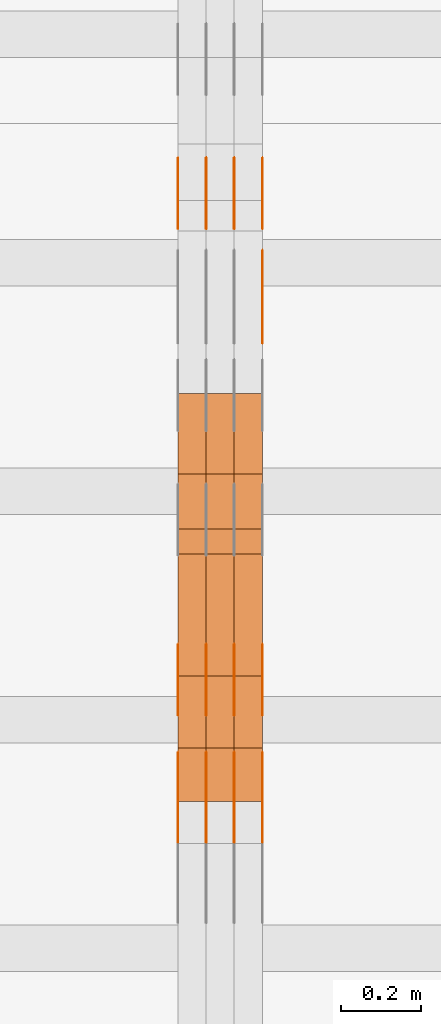
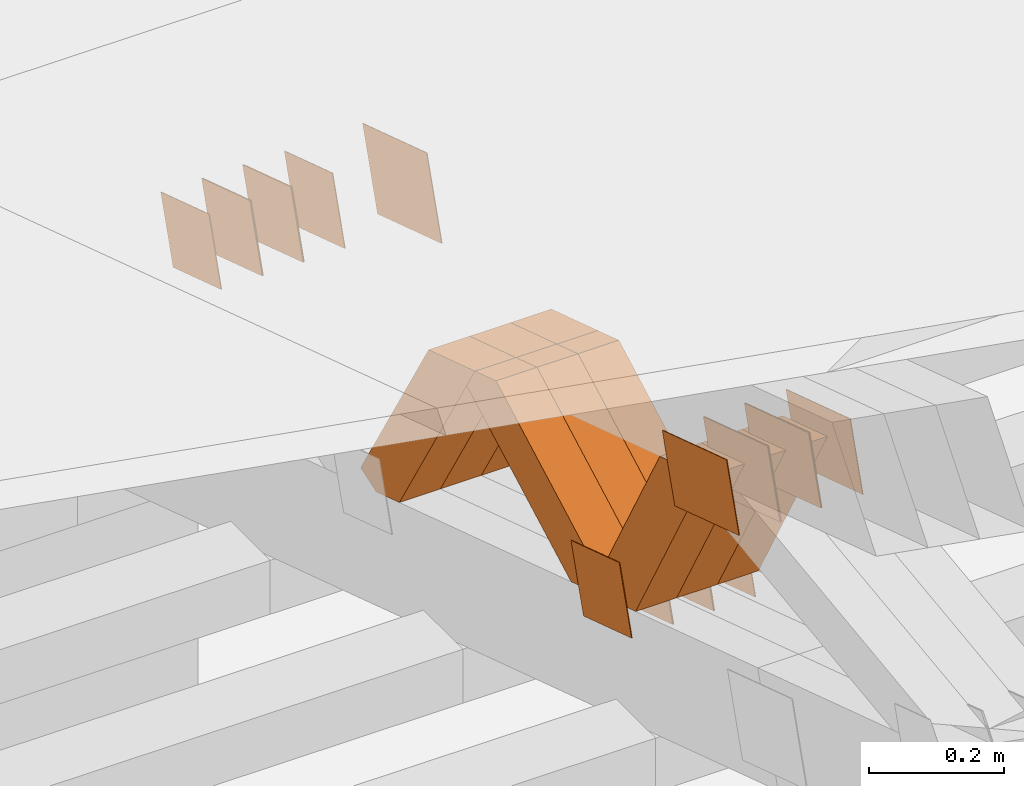
# One storey, part 210 of 385: 28 proxies.
"""IFC2X3 building model written with IfcOpenShell, lengths in millimetres."""

from ifc_helpers import new_model, entity, si_unit, converted_unit, derived_unit, direction, frame, origin, place, context, subcontext, project, spatial, polyline, outline, extrude, source, transform, mapped, material, type_object, type_shapes, element, save


model = new_model("IFC2X3")

# Units and contexts
model_context = context("Model", 3, precision=0.01, world=origin(), true_north=direction((6.12303176911189e-17, 1.0)))
body_context = subcontext(model_context, "Body", "Model", "MODEL_VIEW")
ifc_project = project(units=[si_unit("LENGTHUNIT", "METRE", prefix="MILLI"), si_unit("AREAUNIT", "SQUARE_METRE"), si_unit("VOLUMEUNIT", "CUBIC_METRE"), converted_unit("PLANEANGLEUNIT", "DEGREE", entity("IfcRatioMeasure", 0.0174532925199433), si_unit("PLANEANGLEUNIT", "RADIAN"), dimensions=[0, 0, 0, 0, 0, 0, 0]), si_unit("MASSUNIT", "GRAM", prefix="KILO"), derived_unit("MASSDENSITYUNIT", [(si_unit("MASSUNIT", "GRAM", prefix="KILO"), 1), (si_unit("LENGTHUNIT", "METRE"), -3)]), si_unit("TIMEUNIT", "SECOND"), si_unit("FREQUENCYUNIT", "HERTZ"), si_unit("THERMODYNAMICTEMPERATUREUNIT", "DEGREE_CELSIUS"), derived_unit("THERMALTRANSMITTANCEUNIT", [(si_unit("MASSUNIT", "GRAM", prefix="KILO"), 1), (si_unit("THERMODYNAMICTEMPERATUREUNIT", "KELVIN"), -1), (si_unit("TIMEUNIT", "SECOND"), -3)]), derived_unit("VOLUMETRICFLOWRATEUNIT", [(si_unit("LENGTHUNIT", "METRE"), 3), (si_unit("TIMEUNIT", "SECOND"), -1)]), si_unit("ELECTRICCURRENTUNIT", "AMPERE"), si_unit("ELECTRICVOLTAGEUNIT", "VOLT"), si_unit("POWERUNIT", "WATT"), si_unit("FORCEUNIT", "NEWTON", prefix="KILO"), si_unit("ILLUMINANCEUNIT", "LUX"), si_unit("LUMINOUSFLUXUNIT", "LUMEN"), si_unit("LUMINOUSINTENSITYUNIT", "CANDELA"), derived_unit("USERDEFINED", [(si_unit("MASSUNIT", "GRAM", prefix="KILO"), -1), (si_unit("LENGTHUNIT", "METRE"), -2), (si_unit("TIMEUNIT", "SECOND"), 3), (si_unit("LUMINOUSFLUXUNIT", "LUMEN"), 1)]), derived_unit("LINEARVELOCITYUNIT", [(si_unit("LENGTHUNIT", "METRE"), 1), (si_unit("TIMEUNIT", "SECOND"), -1)]), si_unit("PRESSUREUNIT", "PASCAL"), derived_unit("USERDEFINED", [(si_unit("LENGTHUNIT", "METRE"), -2), (si_unit("MASSUNIT", "GRAM", prefix="KILO"), 1), (si_unit("TIMEUNIT", "SECOND"), -2)])], contexts=[model_context])

# Site, building, storey
site_placement = place(None, origin())
site = spatial("IfcSite", under=ifc_project, at=site_placement, CompositionType="ELEMENT")
building_placement = place(site_placement, origin())
building = spatial("IfcBuilding", under=site, at=building_placement, CompositionType="ELEMENT")
storey_placement = place(building_placement, origin())
storey = spatial("IfcBuildingStorey", under=building, at=storey_placement, Name="Default", CompositionType="ELEMENT", Elevation=0.0)

# Proxies
ifc_material_1 = material(Name="IfcSurfaceStyle #246650")
building_element_proxy_type_1 = type_object("IfcBuildingElementProxyType", PredefinedType="NOTDEFINED", material=ifc_material_1)
shared_shape_1 = source(origin(), body_context, "Body", "SweptSolid", [
    extrude(outline(polyline([(-74.9998605591059, -59.9999264677526), (74.999875428623, -59.9999264677526), (74.9998605591068, 59.9999264677526), (-74.9998754286239, 59.9999264677526), (-74.9998605591059, -59.9999264677526)])), frame((75.0000889884782, 60.0000460315623, 0.0), z_axis=(0.0, 0.0, 1.0), x_axis=(-1.0, 0.0, 0.0)), (0.0, 0.0, 1.0), 1.3),
])
type_shapes(building_element_proxy_type_1, [shared_shape_1])
proxy_1_placement = place(building_placement, frame((18386.3, 20621.9679769682, 2241.76551219004), z_axis=(-1.0, 0.0, 0.0), x_axis=(0.0, -0.951056516295154, 0.309016994374948)))
element("IfcBuildingElementProxy", 1, at=proxy_1_placement, inside=storey, type_object=building_element_proxy_type_1, material=ifc_material_1, context=body_context, shape_type="MappedRepresentation", body=[
    mapped(shared_shape_1, transform((0.0, 0.0, 0.0), scale=1.0)),
])
ifc_material_2 = material(Name="IfcSurfaceStyle #246593")
building_element_proxy_type_2 = type_object("IfcBuildingElementProxyType", PredefinedType="NOTDEFINED", material=ifc_material_2)
shared_shape_2 = source(origin(), body_context, "Body", "SweptSolid", [
    extrude(outline(polyline([(-74.9998605591059, -59.9999264677526), (74.999875428623, -59.9999264677526), (74.9998605591068, 59.9999264677526), (-74.9998754286239, 59.9999264677526), (-74.9998605591059, -59.9999264677526)])), frame((75.0000889884782, 60.0000460315623, 0.0), z_axis=(0.0, 0.0, 1.0), x_axis=(-1.0, 0.0, 0.0)), (0.0, 0.0, 1.0), 1.3),
])
type_shapes(building_element_proxy_type_2, [shared_shape_2])
proxy_2_placement = place(building_placement, frame((18315.0, 20621.9679769682, 2241.76551219004), z_axis=(-1.0, 0.0, 0.0), x_axis=(0.0, -0.951056516295154, 0.309016994374948)))
element("IfcBuildingElementProxy", 2, at=proxy_2_placement, inside=storey, type_object=building_element_proxy_type_2, material=ifc_material_2, context=body_context, shape_type="MappedRepresentation", body=[
    mapped(shared_shape_2, transform((0.0, 0.0, 0.0), scale=1.0)),
])
ifc_material_3 = material(Name="IfcSurfaceStyle #246536")
building_element_proxy_type_3 = type_object("IfcBuildingElementProxyType", PredefinedType="NOTDEFINED", material=ifc_material_3)
shared_shape_3 = source(origin(), body_context, "Body", "SweptSolid", [
    extrude(outline(polyline([(-74.9998605591059, -59.9999264677526), (74.999875428623, -59.9999264677526), (74.9998605591068, 59.9999264677526), (-74.9998754286239, 59.9999264677526), (-74.9998605591059, -59.9999264677526)])), frame((75.0000889884782, 60.0000460315623, 0.0), z_axis=(0.0, 0.0, 1.0), x_axis=(-1.0, 0.0, 0.0)), (0.0, 0.0, 1.0), 1.3),
])
type_shapes(building_element_proxy_type_3, [shared_shape_3])
proxy_3_placement = place(building_placement, frame((18316.3, 20621.9679769682, 2241.76551219004), z_axis=(-1.0, 0.0, 0.0), x_axis=(0.0, -0.951056516295154, 0.309016994374948)))
element("IfcBuildingElementProxy", 3, at=proxy_3_placement, inside=storey, type_object=building_element_proxy_type_3, material=ifc_material_3, context=body_context, shape_type="MappedRepresentation", body=[
    mapped(shared_shape_3, transform((0.0, 0.0, 0.0), scale=1.0)),
])
ifc_material_4 = material(Name="IfcSurfaceStyle #246479")
building_element_proxy_type_4 = type_object("IfcBuildingElementProxyType", PredefinedType="NOTDEFINED", material=ifc_material_4)
shared_shape_4 = source(origin(), body_context, "Body", "SweptSolid", [
    extrude(outline(polyline([(-74.9998605591059, -59.9999264677526), (74.999875428623, -59.9999264677526), (74.9998605591068, 59.9999264677526), (-74.9998754286239, 59.9999264677526), (-74.9998605591059, -59.9999264677526)])), frame((75.0000889884782, 60.0000460315623, 0.0), z_axis=(0.0, 0.0, 1.0), x_axis=(-1.0, 0.0, 0.0)), (0.0, 0.0, 1.0), 1.29999999999999),
])
type_shapes(building_element_proxy_type_4, [shared_shape_4])
proxy_4_placement = place(building_placement, frame((18245.0, 20621.9679769682, 2241.76551219004), z_axis=(-1.0, 0.0, 0.0), x_axis=(0.0, -0.951056516295154, 0.309016994374948)))
element("IfcBuildingElementProxy", 4, at=proxy_4_placement, inside=storey, type_object=building_element_proxy_type_4, material=ifc_material_4, context=body_context, shape_type="MappedRepresentation", body=[
    mapped(shared_shape_4, transform((0.0, 0.0, 0.0), scale=1.0)),
])
ifc_material_5 = material(Name="IfcSurfaceStyle #246422")
building_element_proxy_type_5 = type_object("IfcBuildingElementProxyType", PredefinedType="NOTDEFINED", material=ifc_material_5)
shared_shape_5 = source(origin(), body_context, "Body", "SweptSolid", [
    extrude(outline(polyline([(-74.9998605591059, -59.9999264677526), (74.999875428623, -59.9999264677526), (74.9998605591068, 59.9999264677526), (-74.9998754286239, 59.9999264677526), (-74.9998605591059, -59.9999264677526)])), frame((75.0000889884782, 60.0000460315623, 0.0), z_axis=(0.0, 0.0, 1.0), x_axis=(-1.0, 0.0, 0.0)), (0.0, 0.0, 1.0), 1.29999999999999),
])
type_shapes(building_element_proxy_type_5, [shared_shape_5])
proxy_5_placement = place(building_placement, frame((18246.3, 20621.9679769682, 2241.76551219004), z_axis=(-1.0, 0.0, 0.0), x_axis=(0.0, -0.951056516295154, 0.309016994374948)))
element("IfcBuildingElementProxy", 5, at=proxy_5_placement, inside=storey, type_object=building_element_proxy_type_5, material=ifc_material_5, context=body_context, shape_type="MappedRepresentation", body=[
    mapped(shared_shape_5, transform((0.0, 0.0, 0.0), scale=1.0)),
])
ifc_material_6 = material(Name="IfcSurfaceStyle #246365")
building_element_proxy_type_6 = type_object("IfcBuildingElementProxyType", PredefinedType="NOTDEFINED", material=ifc_material_6)
shared_shape_6 = source(origin(), body_context, "Body", "SweptSolid", [
    extrude(outline(polyline([(-74.9998605591059, -59.9999264677526), (74.999875428623, -59.9999264677526), (74.9998605591068, 59.9999264677526), (-74.9998754286239, 59.9999264677526), (-74.9998605591059, -59.9999264677526)])), frame((75.0000889884782, 60.0000460315623, 0.0), z_axis=(0.0, 0.0, 1.0), x_axis=(-1.0, 0.0, 0.0)), (0.0, 0.0, 1.0), 1.29999999999999),
])
type_shapes(building_element_proxy_type_6, [shared_shape_6])
proxy_6_placement = place(building_placement, frame((18175.0, 20621.9679769682, 2241.76551219004), z_axis=(-1.0, 0.0, 0.0), x_axis=(0.0, -0.951056516295154, 0.309016994374948)))
element("IfcBuildingElementProxy", 6, at=proxy_6_placement, inside=storey, type_object=building_element_proxy_type_6, material=ifc_material_6, context=body_context, shape_type="MappedRepresentation", body=[
    mapped(shared_shape_6, transform((0.0, 0.0, 0.0), scale=1.0)),
])
ifc_material_7 = material(Name="IfcSurfaceStyle #244940")
building_element_proxy_type_7 = type_object("IfcBuildingElementProxyType", PredefinedType="NOTDEFINED", material=ifc_material_7)
shared_shape_7 = source(origin(), body_context, "Body", "SweptSolid", [
    extrude(outline(polyline([(-100.000260677523, -72.0000050220369), (100.000341220114, -72.0000050220369), (99.9997962944585, 72.0000050220369), (-99.9998768370492, 72.0000050220369), (-100.000260677523, -72.0000050220369)])), frame((100.000341220114, 72.0001826453454, 0.0), z_axis=(0.0, 0.0, 1.0), x_axis=(-1.0, 0.0, 0.0)), (0.0, 0.0, 1.0), 1.3),
])
type_shapes(building_element_proxy_type_7, [shared_shape_7])
proxy_7_placement = place(building_placement, frame((18386.3, 20382.8706354426, 2409.35285895246), z_axis=(-1.0, 0.0, 0.0), x_axis=(0.0, -0.951056516295154, 0.309016994374948)))
element("IfcBuildingElementProxy", 7, at=proxy_7_placement, inside=storey, type_object=building_element_proxy_type_7, material=ifc_material_7, context=body_context, shape_type="MappedRepresentation", body=[
    mapped(shared_shape_7, transform((0.0, 0.0, 0.0), scale=1.0)),
])
ifc_material_8 = material(Name="IfcSurfaceStyle #243914")
building_element_proxy_type_8 = type_object("IfcBuildingElementProxyType", PredefinedType="NOTDEFINED", material=ifc_material_8)
shared_shape_8 = source(origin(), body_context, "Body", "SweptSolid", [
    extrude(outline(polyline([(-99.9998479918963, -59.9999913366637), (99.9998251396114, -59.9999913366637), (99.9998102700952, 59.9999913366637), (-99.9997874178102, 59.9999913366637), (-99.9998479918963, -59.9999913366637)])), frame((99.9998251396114, 60.0000609537942, 0.0), z_axis=(0.0, 0.0, 1.0), x_axis=(-1.0, 0.0, 0.0)), (0.0, 0.0, 1.0), 1.3),
])
type_shapes(building_element_proxy_type_8, [shared_shape_8])
proxy_8_placement = place(building_placement, frame((18386.3, 19136.9072023289, 2711.67346128215), z_axis=(-1.0, 0.0, 0.0), x_axis=(0.0, -0.951056516295154, 0.309016994374948)))
element("IfcBuildingElementProxy", 8, at=proxy_8_placement, inside=storey, type_object=building_element_proxy_type_8, material=ifc_material_8, context=body_context, shape_type="MappedRepresentation", body=[
    mapped(shared_shape_8, transform((0.0, 0.0, 0.0), scale=1.0)),
])
ifc_material_9 = material(Name="IfcSurfaceStyle #243857")
building_element_proxy_type_9 = type_object("IfcBuildingElementProxyType", PredefinedType="NOTDEFINED", material=ifc_material_9)
shared_shape_9 = source(origin(), body_context, "Body", "SweptSolid", [
    extrude(outline(polyline([(-99.9998479918963, -59.9999913366637), (99.9998251396114, -59.9999913366637), (99.9998102700952, 59.9999913366637), (-99.9997874178102, 59.9999913366637), (-99.9998479918963, -59.9999913366637)])), frame((99.9998251396114, 60.0000609537942, 0.0), z_axis=(0.0, 0.0, 1.0), x_axis=(-1.0, 0.0, 0.0)), (0.0, 0.0, 1.0), 1.3),
])
type_shapes(building_element_proxy_type_9, [shared_shape_9])
proxy_9_placement = place(building_placement, frame((18315.0, 19136.9072023289, 2711.67346128215), z_axis=(-1.0, 0.0, 0.0), x_axis=(0.0, -0.951056516295154, 0.309016994374948)))
element("IfcBuildingElementProxy", 9, at=proxy_9_placement, inside=storey, type_object=building_element_proxy_type_9, material=ifc_material_9, context=body_context, shape_type="MappedRepresentation", body=[
    mapped(shared_shape_9, transform((0.0, 0.0, 0.0), scale=1.0)),
])
ifc_material_10 = material(Name="IfcSurfaceStyle #243800")
building_element_proxy_type_10 = type_object("IfcBuildingElementProxyType", PredefinedType="NOTDEFINED", material=ifc_material_10)
shared_shape_10 = source(origin(), body_context, "Body", "SweptSolid", [
    extrude(outline(polyline([(-99.9998479918963, -59.9999913366637), (99.9998251396114, -59.9999913366637), (99.9998102700952, 59.9999913366637), (-99.9997874178102, 59.9999913366637), (-99.9998479918963, -59.9999913366637)])), frame((99.9998251396114, 60.0000609537942, 0.0), z_axis=(0.0, 0.0, 1.0), x_axis=(-1.0, 0.0, 0.0)), (0.0, 0.0, 1.0), 1.3),
])
type_shapes(building_element_proxy_type_10, [shared_shape_10])
proxy_10_placement = place(building_placement, frame((18316.3, 19136.9072023289, 2711.67346128215), z_axis=(-1.0, 0.0, 0.0), x_axis=(0.0, -0.951056516295154, 0.309016994374948)))
element("IfcBuildingElementProxy", 10, at=proxy_10_placement, inside=storey, type_object=building_element_proxy_type_10, material=ifc_material_10, context=body_context, shape_type="MappedRepresentation", body=[
    mapped(shared_shape_10, transform((0.0, 0.0, 0.0), scale=1.0)),
])
ifc_material_11 = material(Name="IfcSurfaceStyle #243743")
building_element_proxy_type_11 = type_object("IfcBuildingElementProxyType", PredefinedType="NOTDEFINED", material=ifc_material_11)
shared_shape_11 = source(origin(), body_context, "Body", "SweptSolid", [
    extrude(outline(polyline([(-99.9998479918963, -59.9999913366637), (99.9998251396114, -59.9999913366637), (99.9998102700952, 59.9999913366637), (-99.9997874178102, 59.9999913366637), (-99.9998479918963, -59.9999913366637)])), frame((99.9998251396114, 60.0000609537942, 0.0), z_axis=(0.0, 0.0, 1.0), x_axis=(-1.0, 0.0, 0.0)), (0.0, 0.0, 1.0), 1.29999999999998),
])
type_shapes(building_element_proxy_type_11, [shared_shape_11])
proxy_11_placement = place(building_placement, frame((18245.0, 19136.9072023289, 2711.67346128215), z_axis=(-1.0, 0.0, 0.0), x_axis=(0.0, -0.951056516295154, 0.309016994374948)))
element("IfcBuildingElementProxy", 11, at=proxy_11_placement, inside=storey, type_object=building_element_proxy_type_11, material=ifc_material_11, context=body_context, shape_type="MappedRepresentation", body=[
    mapped(shared_shape_11, transform((0.0, 0.0, 0.0), scale=1.0)),
])
ifc_material_12 = material(Name="IfcSurfaceStyle #243686")
building_element_proxy_type_12 = type_object("IfcBuildingElementProxyType", PredefinedType="NOTDEFINED", material=ifc_material_12)
shared_shape_12 = source(origin(), body_context, "Body", "SweptSolid", [
    extrude(outline(polyline([(-99.9998479918963, -59.9999913366637), (99.9998251396114, -59.9999913366637), (99.9998102700952, 59.9999913366637), (-99.9997874178102, 59.9999913366637), (-99.9998479918963, -59.9999913366637)])), frame((99.9998251396114, 60.0000609537942, 0.0), z_axis=(0.0, 0.0, 1.0), x_axis=(-1.0, 0.0, 0.0)), (0.0, 0.0, 1.0), 1.29999999999998),
])
type_shapes(building_element_proxy_type_12, [shared_shape_12])
proxy_12_placement = place(building_placement, frame((18246.3, 19136.9072023289, 2711.67346128215), z_axis=(-1.0, 0.0, 0.0), x_axis=(0.0, -0.951056516295154, 0.309016994374948)))
element("IfcBuildingElementProxy", 12, at=proxy_12_placement, inside=storey, type_object=building_element_proxy_type_12, material=ifc_material_12, context=body_context, shape_type="MappedRepresentation", body=[
    mapped(shared_shape_12, transform((0.0, 0.0, 0.0), scale=1.0)),
])
ifc_material_13 = material(Name="IfcSurfaceStyle #243629")
building_element_proxy_type_13 = type_object("IfcBuildingElementProxyType", PredefinedType="NOTDEFINED", material=ifc_material_13)
shared_shape_13 = source(origin(), body_context, "Body", "SweptSolid", [
    extrude(outline(polyline([(-99.9998479918963, -59.9999913366637), (99.9998251396114, -59.9999913366637), (99.9998102700952, 59.9999913366637), (-99.9997874178102, 59.9999913366637), (-99.9998479918963, -59.9999913366637)])), frame((99.9998251396114, 60.0000609537942, 0.0), z_axis=(0.0, 0.0, 1.0), x_axis=(-1.0, 0.0, 0.0)), (0.0, 0.0, 1.0), 1.29999999999999),
])
type_shapes(building_element_proxy_type_13, [shared_shape_13])
proxy_13_placement = place(building_placement, frame((18175.0, 19136.9072023289, 2711.67346128215), z_axis=(-1.0, 0.0, 0.0), x_axis=(0.0, -0.951056516295154, 0.309016994374948)))
element("IfcBuildingElementProxy", 13, at=proxy_13_placement, inside=storey, type_object=building_element_proxy_type_13, material=ifc_material_13, context=body_context, shape_type="MappedRepresentation", body=[
    mapped(shared_shape_13, transform((0.0, 0.0, 0.0), scale=1.0)),
])
ifc_material_14 = material(Name="IfcSurfaceStyle #238784")
building_element_proxy_type_14 = type_object("IfcBuildingElementProxyType", PredefinedType="NOTDEFINED", material=ifc_material_14)
shared_shape_14 = source(origin(), body_context, "Body", "SweptSolid", [
    extrude(outline(polyline([(-74.9998605591127, -59.9999264677599), (74.999875428618, -59.9999264677599), (74.9998605591127, 59.9999264677599), (-74.999875428618, 59.9999264677599), (-74.9998605591127, -59.9999264677599)])), frame((75.0002655673825, 60.0000016373433, 0.0), z_axis=(0.0, 0.0, 1.0), x_axis=(-1.0, 0.0, 0.0)), (0.0, 0.0, 1.0), 1.3),
])
type_shapes(building_element_proxy_type_14, [shared_shape_14])
proxy_14_placement = place(building_placement, frame((18386.3, 19407.1136664358, 2348.71056820494), z_axis=(-1.0, 0.0, 0.0), x_axis=(0.0, -0.951056516295124, 0.309016994375039)))
element("IfcBuildingElementProxy", 14, at=proxy_14_placement, inside=storey, type_object=building_element_proxy_type_14, material=ifc_material_14, context=body_context, shape_type="MappedRepresentation", body=[
    mapped(shared_shape_14, transform((0.0, 0.0, 0.0), scale=1.0)),
])
ifc_material_15 = material(Name="IfcSurfaceStyle #238727")
building_element_proxy_type_15 = type_object("IfcBuildingElementProxyType", PredefinedType="NOTDEFINED", material=ifc_material_15)
shared_shape_15 = source(origin(), body_context, "Body", "SweptSolid", [
    extrude(outline(polyline([(-74.9998605591127, -59.9999264677599), (74.999875428618, -59.9999264677599), (74.9998605591127, 59.9999264677599), (-74.999875428618, 59.9999264677599), (-74.9998605591127, -59.9999264677599)])), frame((75.0002655673825, 60.0000016373433, 0.0), z_axis=(0.0, 0.0, 1.0), x_axis=(-1.0, 0.0, 0.0)), (0.0, 0.0, 1.0), 1.3),
])
type_shapes(building_element_proxy_type_15, [shared_shape_15])
proxy_15_placement = place(building_placement, frame((18315.0, 19407.1136664358, 2348.71056820494), z_axis=(-1.0, 0.0, 0.0), x_axis=(0.0, -0.951056516295124, 0.309016994375039)))
element("IfcBuildingElementProxy", 15, at=proxy_15_placement, inside=storey, type_object=building_element_proxy_type_15, material=ifc_material_15, context=body_context, shape_type="MappedRepresentation", body=[
    mapped(shared_shape_15, transform((0.0, 0.0, 0.0), scale=1.0)),
])
ifc_material_16 = material(Name="IfcSurfaceStyle #238670")
building_element_proxy_type_16 = type_object("IfcBuildingElementProxyType", PredefinedType="NOTDEFINED", material=ifc_material_16)
shared_shape_16 = source(origin(), body_context, "Body", "SweptSolid", [
    extrude(outline(polyline([(-74.9998605591127, -59.9999264677599), (74.999875428618, -59.9999264677599), (74.9998605591127, 59.9999264677599), (-74.999875428618, 59.9999264677599), (-74.9998605591127, -59.9999264677599)])), frame((75.0002655673825, 60.0000016373433, 0.0), z_axis=(0.0, 0.0, 1.0), x_axis=(-1.0, 0.0, 0.0)), (0.0, 0.0, 1.0), 1.3),
])
type_shapes(building_element_proxy_type_16, [shared_shape_16])
proxy_16_placement = place(building_placement, frame((18316.3, 19407.1136664358, 2348.71056820494), z_axis=(-1.0, 0.0, 0.0), x_axis=(0.0, -0.951056516295124, 0.309016994375039)))
element("IfcBuildingElementProxy", 16, at=proxy_16_placement, inside=storey, type_object=building_element_proxy_type_16, material=ifc_material_16, context=body_context, shape_type="MappedRepresentation", body=[
    mapped(shared_shape_16, transform((0.0, 0.0, 0.0), scale=1.0)),
])
ifc_material_17 = material(Name="IfcSurfaceStyle #238613")
building_element_proxy_type_17 = type_object("IfcBuildingElementProxyType", PredefinedType="NOTDEFINED", material=ifc_material_17)
shared_shape_17 = source(origin(), body_context, "Body", "SweptSolid", [
    extrude(outline(polyline([(-74.9998605591127, -59.9999264677599), (74.999875428618, -59.9999264677599), (74.9998605591127, 59.9999264677599), (-74.999875428618, 59.9999264677599), (-74.9998605591127, -59.9999264677599)])), frame((75.0002655673825, 60.0000016373433, 0.0), z_axis=(0.0, 0.0, 1.0), x_axis=(-1.0, 0.0, 0.0)), (0.0, 0.0, 1.0), 1.29999999999999),
])
type_shapes(building_element_proxy_type_17, [shared_shape_17])
proxy_17_placement = place(building_placement, frame((18245.0, 19407.1136664358, 2348.71056820494), z_axis=(-1.0, 0.0, 0.0), x_axis=(0.0, -0.951056516295124, 0.309016994375039)))
element("IfcBuildingElementProxy", 17, at=proxy_17_placement, inside=storey, type_object=building_element_proxy_type_17, material=ifc_material_17, context=body_context, shape_type="MappedRepresentation", body=[
    mapped(shared_shape_17, transform((0.0, 0.0, 0.0), scale=1.0)),
])
ifc_material_18 = material(Name="IfcSurfaceStyle #238556")
building_element_proxy_type_18 = type_object("IfcBuildingElementProxyType", PredefinedType="NOTDEFINED", material=ifc_material_18)
shared_shape_18 = source(origin(), body_context, "Body", "SweptSolid", [
    extrude(outline(polyline([(-74.9998605591127, -59.9999264677599), (74.999875428618, -59.9999264677599), (74.9998605591127, 59.9999264677599), (-74.999875428618, 59.9999264677599), (-74.9998605591127, -59.9999264677599)])), frame((75.0002655673825, 60.0000016373433, 0.0), z_axis=(0.0, 0.0, 1.0), x_axis=(-1.0, 0.0, 0.0)), (0.0, 0.0, 1.0), 1.29999999999999),
])
type_shapes(building_element_proxy_type_18, [shared_shape_18])
proxy_18_placement = place(building_placement, frame((18246.3, 19407.1136664358, 2348.71056820494), z_axis=(-1.0, 0.0, 0.0), x_axis=(0.0, -0.951056516295124, 0.309016994375039)))
element("IfcBuildingElementProxy", 18, at=proxy_18_placement, inside=storey, type_object=building_element_proxy_type_18, material=ifc_material_18, context=body_context, shape_type="MappedRepresentation", body=[
    mapped(shared_shape_18, transform((0.0, 0.0, 0.0), scale=1.0)),
])
ifc_material_19 = material(Name="IfcSurfaceStyle #238499")
building_element_proxy_type_19 = type_object("IfcBuildingElementProxyType", PredefinedType="NOTDEFINED", material=ifc_material_19)
shared_shape_19 = source(origin(), body_context, "Body", "SweptSolid", [
    extrude(outline(polyline([(-74.9998605591127, -59.9999264677599), (74.999875428618, -59.9999264677599), (74.9998605591127, 59.9999264677599), (-74.999875428618, 59.9999264677599), (-74.9998605591127, -59.9999264677599)])), frame((75.0002655673825, 60.0000016373433, 0.0), z_axis=(0.0, 0.0, 1.0), x_axis=(-1.0, 0.0, 0.0)), (0.0, 0.0, 1.0), 1.29999999999999),
])
type_shapes(building_element_proxy_type_19, [shared_shape_19])
proxy_19_placement = place(building_placement, frame((18175.0, 19407.1136664358, 2348.71056820494), z_axis=(-1.0, 0.0, 0.0), x_axis=(0.0, -0.951056516295124, 0.309016994375039)))
element("IfcBuildingElementProxy", 19, at=proxy_19_placement, inside=storey, type_object=building_element_proxy_type_19, material=ifc_material_19, context=body_context, shape_type="MappedRepresentation", body=[
    mapped(shared_shape_19, transform((0.0, 0.0, 0.0), scale=1.0)),
])
ifc_material_20 = material(Name="IfcSurfaceStyle #222026")
building_element_proxy_type_20 = type_object("IfcBuildingElementProxyType", Name="T1-W40 222024", PredefinedType="NOTDEFINED", material=ifc_material_20)
shared_shape_20 = source(origin(), body_context, "Body", "SweptSolid", [
    extrude(outline(polyline([(-190.697067347251, -47.4992767218045), (178.704677543904, -47.4992767218045), (178.119540532346, -0.000296092407564622), (126.935785980356, 47.4999913795318), (-293.062936709355, 47.4988581564849), (-190.697067347251, -47.4992767218045)])), frame((178.7049897723, 47.4999913795318, 0.0), z_axis=(0.0, 0.0, 1.0), x_axis=(-1.0, 0.0, 0.0)), (0.0, 0.0, 1.0), 70.0),
])
type_shapes(building_element_proxy_type_20, [shared_shape_20])
proxy_20_placement = place(building_placement, frame((18385.0, 19280.269490882, 2403.36730959494), z_axis=(-1.0, 0.0, 0.0), x_axis=(0.0, -0.48691092455798, 0.873451630913866)))
element("IfcBuildingElementProxy", 20, at=proxy_20_placement, inside=storey, type_object=building_element_proxy_type_20, material=ifc_material_20, Name="T1-W40", context=body_context, shape_type="MappedRepresentation", body=[
    mapped(shared_shape_20, transform((0.0, 0.0, 0.0), scale=1.0)),
])
ifc_material_21 = material(Name="IfcSurfaceStyle #221960")
building_element_proxy_type_21 = type_object("IfcBuildingElementProxyType", Name="T1-W40 221958", PredefinedType="NOTDEFINED", material=ifc_material_21)
shared_shape_21 = source(origin(), body_context, "Body", "SweptSolid", [
    extrude(outline(polyline([(-190.697067347251, -47.4992767218045), (178.704677543904, -47.4992767218045), (178.119540532346, -0.000296092407564622), (126.935785980356, 47.4999913795318), (-293.062936709355, 47.4988581564849), (-190.697067347251, -47.4992767218045)])), frame((178.7049897723, 47.4999913795318, 0.0), z_axis=(0.0, 0.0, 1.0), x_axis=(-1.0, 0.0, 0.0)), (0.0, 0.0, 1.0), 70.0),
])
type_shapes(building_element_proxy_type_21, [shared_shape_21])
proxy_21_placement = place(building_placement, frame((18315.0, 19280.269490882, 2403.36730959494), z_axis=(-1.0, 0.0, 0.0), x_axis=(0.0, -0.48691092455798, 0.873451630913866)))
element("IfcBuildingElementProxy", 21, at=proxy_21_placement, inside=storey, type_object=building_element_proxy_type_21, material=ifc_material_21, Name="T1-W40", context=body_context, shape_type="MappedRepresentation", body=[
    mapped(shared_shape_21, transform((0.0, 0.0, 0.0), scale=1.0)),
])
ifc_material_22 = material(Name="IfcSurfaceStyle #221894")
building_element_proxy_type_22 = type_object("IfcBuildingElementProxyType", Name="T1-W40 221892", PredefinedType="NOTDEFINED", material=ifc_material_22)
shared_shape_22 = source(origin(), body_context, "Body", "SweptSolid", [
    extrude(outline(polyline([(-190.697067347251, -47.4992767218045), (178.704677543904, -47.4992767218045), (178.119540532346, -0.000296092407564622), (126.935785980356, 47.4999913795318), (-293.062936709355, 47.4988581564849), (-190.697067347251, -47.4992767218045)])), frame((178.7049897723, 47.4999913795318, 0.0), z_axis=(0.0, 0.0, 1.0), x_axis=(-1.0, 0.0, 0.0)), (0.0, 0.0, 1.0), 70.0),
])
type_shapes(building_element_proxy_type_22, [shared_shape_22])
proxy_22_placement = place(building_placement, frame((18245.0, 19280.269490882, 2403.36730959494), z_axis=(-1.0, 0.0, 0.0), x_axis=(0.0, -0.48691092455798, 0.873451630913866)))
element("IfcBuildingElementProxy", 22, at=proxy_22_placement, inside=storey, type_object=building_element_proxy_type_22, material=ifc_material_22, Name="T1-W40", context=body_context, shape_type="MappedRepresentation", body=[
    mapped(shared_shape_22, transform((0.0, 0.0, 0.0), scale=1.0)),
])
ifc_material_23 = material(Name="IfcSurfaceStyle #221630")
building_element_proxy_type_23 = type_object("IfcBuildingElementProxyType", Name="T1-W47 221628", PredefinedType="NOTDEFINED", material=ifc_material_23)
shared_shape_23 = source(origin(), body_context, "Body", "SweptSolid", [
    extrude(outline(polyline([(-273.154581805017, -47.5000119135351), (121.157675769026, -47.5000119135351), (166.341960897813, -0.000128144957132403), (168.441931699108, 47.5000759860137), (-182.78698656093, 47.5000759860137), (-273.154581805017, -47.5000119135351)])), frame((168.441931699108, 47.5000759860137, 0.0), z_axis=(0.0, 0.0, 1.0), x_axis=(-1.0, 0.0, 0.0)), (0.0, 0.0, 1.0), 70.0),
])
type_shapes(building_element_proxy_type_23, [shared_shape_23])
proxy_23_placement = place(building_placement, frame((18385.0, 19755.0380859375, 2553.712890625), z_axis=(-1.0, 0.0, 0.0), x_axis=(0.0, -0.879386813332609, -0.476108005117242)))
element("IfcBuildingElementProxy", 23, at=proxy_23_placement, inside=storey, type_object=building_element_proxy_type_23, material=ifc_material_23, Name="T1-W47", context=body_context, shape_type="MappedRepresentation", body=[
    mapped(shared_shape_23, transform((0.0, 0.0, 0.0), scale=1.0)),
])
ifc_material_24 = material(Name="IfcSurfaceStyle #221564")
building_element_proxy_type_24 = type_object("IfcBuildingElementProxyType", Name="T1-W47 221562", PredefinedType="NOTDEFINED", material=ifc_material_24)
shared_shape_24 = source(origin(), body_context, "Body", "SweptSolid", [
    extrude(outline(polyline([(-273.154581805017, -47.5000119135351), (121.157675769026, -47.5000119135351), (166.341960897813, -0.000128144957132403), (168.441931699108, 47.5000759860137), (-182.78698656093, 47.5000759860137), (-273.154581805017, -47.5000119135351)])), frame((168.441931699108, 47.5000759860137, 0.0), z_axis=(0.0, 0.0, 1.0), x_axis=(-1.0, 0.0, 0.0)), (0.0, 0.0, 1.0), 70.0),
])
type_shapes(building_element_proxy_type_24, [shared_shape_24])
proxy_24_placement = place(building_placement, frame((18315.0, 19755.0380859375, 2553.712890625), z_axis=(-1.0, 0.0, 0.0), x_axis=(0.0, -0.879386813332609, -0.476108005117242)))
element("IfcBuildingElementProxy", 24, at=proxy_24_placement, inside=storey, type_object=building_element_proxy_type_24, material=ifc_material_24, Name="T1-W47", context=body_context, shape_type="MappedRepresentation", body=[
    mapped(shared_shape_24, transform((0.0, 0.0, 0.0), scale=1.0)),
])
ifc_material_25 = material(Name="IfcSurfaceStyle #221498")
building_element_proxy_type_25 = type_object("IfcBuildingElementProxyType", Name="T1-W47 221496", PredefinedType="NOTDEFINED", material=ifc_material_25)
shared_shape_25 = source(origin(), body_context, "Body", "SweptSolid", [
    extrude(outline(polyline([(-273.154581805017, -47.5000119135351), (121.157675769026, -47.5000119135351), (166.341960897813, -0.000128144957132403), (168.441931699108, 47.5000759860137), (-182.78698656093, 47.5000759860137), (-273.154581805017, -47.5000119135351)])), frame((168.441931699108, 47.5000759860137, 0.0), z_axis=(0.0, 0.0, 1.0), x_axis=(-1.0, 0.0, 0.0)), (0.0, 0.0, 1.0), 70.0),
])
type_shapes(building_element_proxy_type_25, [shared_shape_25])
proxy_25_placement = place(building_placement, frame((18245.0, 19755.0380859375, 2553.712890625), z_axis=(-1.0, 0.0, 0.0), x_axis=(0.0, -0.879386813332609, -0.476108005117242)))
element("IfcBuildingElementProxy", 25, at=proxy_25_placement, inside=storey, type_object=building_element_proxy_type_25, material=ifc_material_25, Name="T1-W47", context=body_context, shape_type="MappedRepresentation", body=[
    mapped(shared_shape_25, transform((0.0, 0.0, 0.0), scale=1.0)),
])
ifc_material_26 = material(Name="IfcSurfaceStyle #221234")
building_element_proxy_type_26 = type_object("IfcBuildingElementProxyType", Name="T1-W34 221232", PredefinedType="NOTDEFINED", material=ifc_material_26)
shared_shape_26 = source(origin(), body_context, "Body", "SweptSolid", [
    extrude(outline(polyline([(-197.657161937088, -47.499796538607), (193.17680883218, -47.499796538607), (182.92464491562, -1.98968224184526e-05), (128.354123102956, 47.4998064870182), (-306.798414913668, 47.4998064870182), (-197.657161937088, -47.499796538607)])), frame((193.176852028916, 47.4998566383869, 0.0), z_axis=(0.0, 0.0, 1.0), x_axis=(-1.0, 0.0, 0.0)), (0.0, 0.0, 1.0), 70.0),
])
type_shapes(building_element_proxy_type_26, [shared_shape_26])
proxy_26_placement = place(building_placement, frame((18385.0, 19987.8030409043, 2165.75390635484), z_axis=(-1.0, 0.0, 0.0), x_axis=(0.0, -0.514479403471631, 0.857502736674044)))
element("IfcBuildingElementProxy", 26, at=proxy_26_placement, inside=storey, type_object=building_element_proxy_type_26, material=ifc_material_26, Name="T1-W34", context=body_context, shape_type="MappedRepresentation", body=[
    mapped(shared_shape_26, transform((0.0, 0.0, 0.0), scale=1.0)),
])
ifc_material_27 = material(Name="IfcSurfaceStyle #221168")
building_element_proxy_type_27 = type_object("IfcBuildingElementProxyType", Name="T1-W34 221166", PredefinedType="NOTDEFINED", material=ifc_material_27)
shared_shape_27 = source(origin(), body_context, "Body", "SweptSolid", [
    extrude(outline(polyline([(-197.657161937088, -47.499796538607), (193.17680883218, -47.499796538607), (182.92464491562, -1.98968224184526e-05), (128.354123102956, 47.4998064870182), (-306.798414913668, 47.4998064870182), (-197.657161937088, -47.499796538607)])), frame((193.176852028916, 47.4998566383869, 0.0), z_axis=(0.0, 0.0, 1.0), x_axis=(-1.0, 0.0, 0.0)), (0.0, 0.0, 1.0), 70.0),
])
type_shapes(building_element_proxy_type_27, [shared_shape_27])
proxy_27_placement = place(building_placement, frame((18315.0, 19987.8030409043, 2165.75390635484), z_axis=(-1.0, 0.0, 0.0), x_axis=(0.0, -0.514479403471631, 0.857502736674044)))
element("IfcBuildingElementProxy", 27, at=proxy_27_placement, inside=storey, type_object=building_element_proxy_type_27, material=ifc_material_27, Name="T1-W34", context=body_context, shape_type="MappedRepresentation", body=[
    mapped(shared_shape_27, transform((0.0, 0.0, 0.0), scale=1.0)),
])
ifc_material_28 = material(Name="IfcSurfaceStyle #221102")
building_element_proxy_type_28 = type_object("IfcBuildingElementProxyType", Name="T1-W34 221100", PredefinedType="NOTDEFINED", material=ifc_material_28)
shared_shape_28 = source(origin(), body_context, "Body", "SweptSolid", [
    extrude(outline(polyline([(-197.657161937088, -47.499796538607), (193.17680883218, -47.499796538607), (182.92464491562, -1.98968224184526e-05), (128.354123102956, 47.4998064870182), (-306.798414913668, 47.4998064870182), (-197.657161937088, -47.499796538607)])), frame((193.176852028916, 47.4998566383869, 0.0), z_axis=(0.0, 0.0, 1.0), x_axis=(-1.0, 0.0, 0.0)), (0.0, 0.0, 1.0), 70.0),
])
type_shapes(building_element_proxy_type_28, [shared_shape_28])
proxy_28_placement = place(building_placement, frame((18245.0, 19987.8030409043, 2165.75390635484), z_axis=(-1.0, 0.0, 0.0), x_axis=(0.0, -0.514479403471631, 0.857502736674044)))
element("IfcBuildingElementProxy", 28, at=proxy_28_placement, inside=storey, type_object=building_element_proxy_type_28, material=ifc_material_28, Name="T1-W34", context=body_context, shape_type="MappedRepresentation", body=[
    mapped(shared_shape_28, transform((0.0, 0.0, 0.0), scale=1.0)),
])

save(model, "model.ifc")
